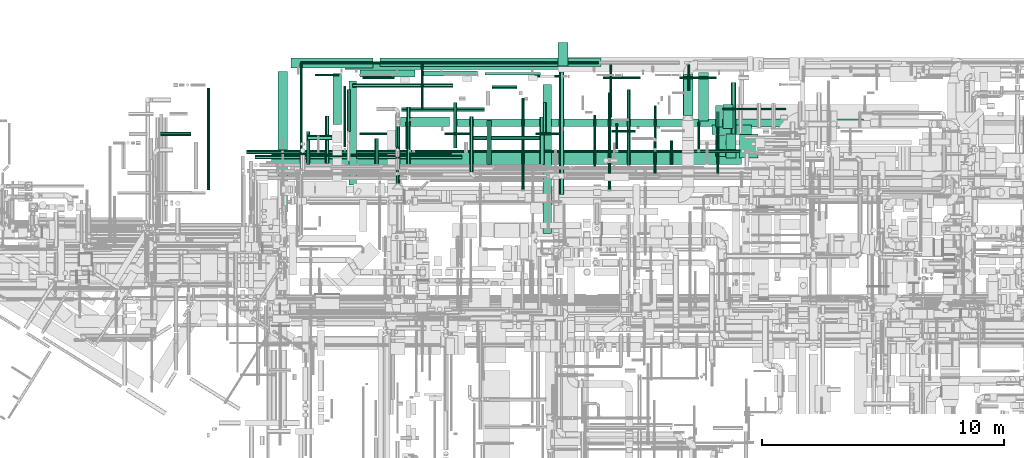
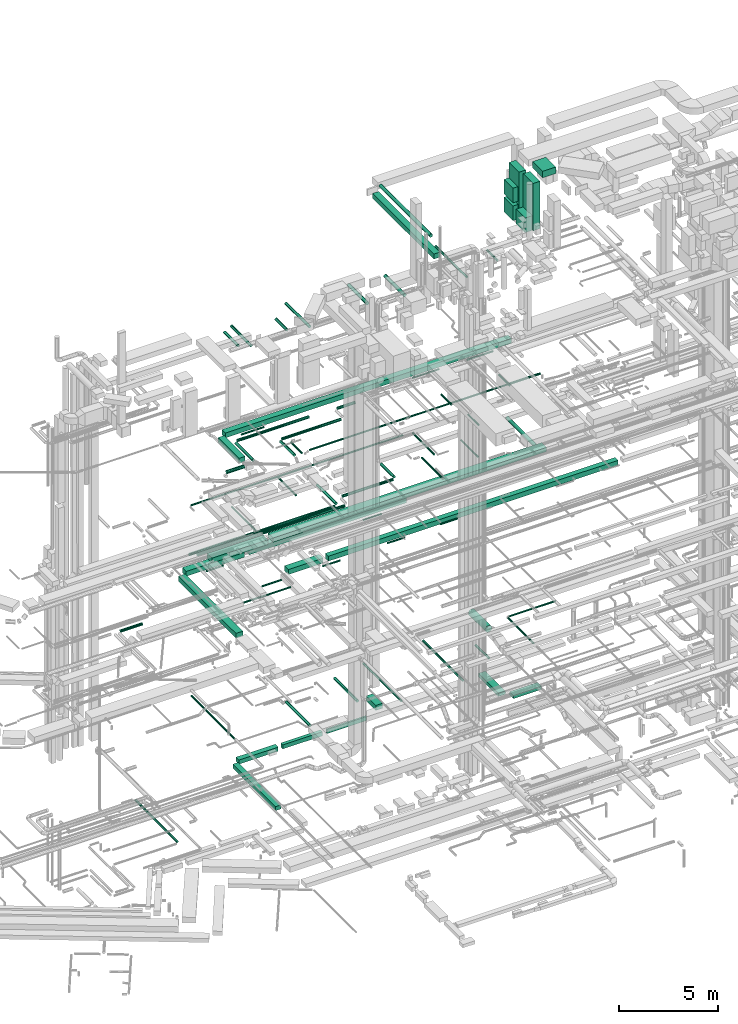
# One storey, part 36 of 337: 77 flow segments.
"""IFC2X3 building model written with IfcOpenShell, lengths in millimetres."""

from ifc_helpers import new_model, entity, si_unit, converted_unit, derived_unit, direction, frame, origin, origin_2d_with_axis, place, context, subcontext, project, spatial, rectangle, circle, extrude, type_object, element, save


model = new_model("IFC2X3")

# Units and contexts
model_context = context("Model", 3, precision=0.01, world=origin(), true_north=direction((6.12303176911189e-17, 1.0)))
body_context = subcontext(model_context, "Body", "Model", "MODEL_VIEW")
ifc_project = project(units=[si_unit("LENGTHUNIT", "METRE", prefix="MILLI"), si_unit("AREAUNIT", "SQUARE_METRE"), si_unit("VOLUMEUNIT", "CUBIC_METRE"), converted_unit("PLANEANGLEUNIT", "DEGREE", entity("IfcRatioMeasure", 0.0174532925199433), si_unit("PLANEANGLEUNIT", "RADIAN"), dimensions=[0, 0, 0, 0, 0, 0, 0]), si_unit("MASSUNIT", "GRAM", prefix="KILO"), derived_unit("MASSDENSITYUNIT", [(si_unit("MASSUNIT", "GRAM", prefix="KILO"), 1), (si_unit("LENGTHUNIT", "METRE"), -3)]), derived_unit("MOMENTOFINERTIAUNIT", [(si_unit("LENGTHUNIT", "METRE"), 4)]), si_unit("TIMEUNIT", "SECOND"), si_unit("FREQUENCYUNIT", "HERTZ"), si_unit("THERMODYNAMICTEMPERATUREUNIT", "DEGREE_CELSIUS"), derived_unit("THERMALTRANSMITTANCEUNIT", [(si_unit("MASSUNIT", "GRAM", prefix="KILO"), 1), (si_unit("THERMODYNAMICTEMPERATUREUNIT", "KELVIN"), -1), (si_unit("TIMEUNIT", "SECOND"), -3)]), derived_unit("VOLUMETRICFLOWRATEUNIT", [(si_unit("LENGTHUNIT", "METRE"), 3), (si_unit("TIMEUNIT", "SECOND"), -1)]), derived_unit("MASSFLOWRATEUNIT", [(si_unit("MASSUNIT", "GRAM", prefix="KILO"), 1), (si_unit("TIMEUNIT", "SECOND"), -1)]), derived_unit("ROTATIONALFREQUENCYUNIT", [(si_unit("TIMEUNIT", "SECOND"), -1)]), si_unit("ELECTRICCURRENTUNIT", "AMPERE"), si_unit("ELECTRICVOLTAGEUNIT", "VOLT"), si_unit("POWERUNIT", "WATT"), si_unit("FORCEUNIT", "NEWTON", prefix="KILO"), si_unit("ILLUMINANCEUNIT", "LUX"), si_unit("LUMINOUSFLUXUNIT", "LUMEN"), si_unit("LUMINOUSINTENSITYUNIT", "CANDELA"), derived_unit("USERDEFINED", [(si_unit("MASSUNIT", "GRAM", prefix="KILO"), -1), (si_unit("LENGTHUNIT", "METRE"), -2), (si_unit("TIMEUNIT", "SECOND"), 3), (si_unit("LUMINOUSFLUXUNIT", "LUMEN"), 1)]), derived_unit("LINEARVELOCITYUNIT", [(si_unit("LENGTHUNIT", "METRE"), 1), (si_unit("TIMEUNIT", "SECOND"), -1)]), si_unit("PRESSUREUNIT", "PASCAL"), derived_unit("USERDEFINED", [(si_unit("LENGTHUNIT", "METRE"), -2), (si_unit("MASSUNIT", "GRAM", prefix="KILO"), 1), (si_unit("TIMEUNIT", "SECOND"), -2)]), derived_unit("LINEARFORCEUNIT", [(si_unit("MASSUNIT", "GRAM", prefix="KILO"), 1), (si_unit("LENGTHUNIT", "METRE"), 1), (si_unit("TIMEUNIT", "SECOND"), -2), (si_unit("LENGTHUNIT", "METRE"), -1)]), derived_unit("PLANARFORCEUNIT", [(si_unit("MASSUNIT", "GRAM", prefix="KILO"), 1), (si_unit("LENGTHUNIT", "METRE"), 1), (si_unit("TIMEUNIT", "SECOND"), -2), (si_unit("LENGTHUNIT", "METRE"), -2)])], contexts=[model_context])

# Site, building, storey
site_placement = place(None, origin())
site = spatial("IfcSite", under=ifc_project, at=site_placement, CompositionType="ELEMENT")
building_placement = place(site_placement, origin())
building = spatial("IfcBuilding", under=site, at=building_placement, CompositionType="ELEMENT")
storey_placement = place(building_placement, origin())
storey = spatial("IfcBuildingStorey", under=building, at=storey_placement, CompositionType="ELEMENT", Elevation=0.0)

# Flow segments
duct_segment_type_1 = type_object("IfcDuctSegmentType", PredefinedType="NOTDEFINED")
flow_segment_1_placement = place(storey_placement, frame((35764.51, 17493.43, -700.0)))
element("IfcFlowSegment", 1, at=flow_segment_1_placement, inside=storey, type_object=duct_segment_type_1, context=body_context, shape_type="SweptSolid", body=[
    extrude(rectangle(XDim=2020.37256000017, YDim=400.0, at=origin_2d_with_axis()), frame((200.0, 1010.19, 0.0), z_axis=(0.0, 0.0, 1.0), x_axis=(0.0, -1.0, 0.0)), (0.0, 0.0, 1.0), 200.0),
])
flow_segment_2_placement = place(storey_placement, frame((21289.2, 14853.13, -1050.0)))
element("IfcFlowSegment", 2, at=flow_segment_2_placement, inside=storey, type_object=duct_segment_type_1, context=body_context, shape_type="SweptSolid", body=[
    extrude(rectangle(XDim=4310.31577104467, YDim=300.000000000001, at=origin_2d_with_axis()), frame((150.0, 2155.16, 0.0), z_axis=(0.0, 0.0, 1.0), x_axis=(0.0, 1.0, 0.0)), (0.0, 0.0, 1.0), 250.0),
])
flow_segment_3_placement = place(storey_placement, frame((26914.66, 19413.45, -1050.0)))
element("IfcFlowSegment", 3, at=flow_segment_3_placement, inside=storey, type_object=duct_segment_type_1, context=body_context, shape_type="SweptSolid", body=[
    extrude(rectangle(XDim=2300.0, YDim=99.9999999999989, at=origin_2d_with_axis()), frame((1150.0, 50.0, 0.0)), (0.0, 0.0, 1.0), 250.0),
])
flow_segment_4_placement = place(storey_placement, frame((21739.2, 19313.45, -1050.0)))
element("IfcFlowSegment", 4, at=flow_segment_4_placement, inside=storey, type_object=duct_segment_type_1, context=body_context, shape_type="SweptSolid", body=[
    extrude(rectangle(XDim=2275.06644000006, YDim=300.000000000001, at=origin_2d_with_axis()), frame((1137.53, 150.0, 0.0)), (0.0, 0.0, 1.0), 250.0),
])
flow_segment_5_placement = place(storey_placement, frame((24314.26, 19363.45, -1050.0)))
element("IfcFlowSegment", 5, at=flow_segment_5_placement, inside=storey, type_object=duct_segment_type_1, context=body_context, shape_type="SweptSolid", body=[
    extrude(rectangle(XDim=2300.39426999994, YDim=200.0, at=origin_2d_with_axis()), frame((1150.2, 100.0, 0.0)), (0.0, 0.0, 1.0), 250.0),
])
flow_segment_6_placement = place(storey_placement, frame((18341.81, 13737.88, 11250.0)))
element("IfcFlowSegment", 6, at=flow_segment_6_placement, inside=storey, type_object=duct_segment_type_1, context=body_context, shape_type="SweptSolid", body=[
    extrude(rectangle(XDim=5813.1806239971, YDim=400.0, at=origin_2d_with_axis()), frame((200.0, 2906.59, 0.0), z_axis=(0.0, 0.0, 1.0), x_axis=(0.0, -1.0, 0.0)), (0.0, 0.0, 1.0), 300.000000000001),
])
flow_segment_7_placement = place(storey_placement, frame((18891.81, 19701.06, 11250.0)))
element("IfcFlowSegment", 7, at=flow_segment_7_placement, inside=storey, type_object=duct_segment_type_1, context=body_context, shape_type="SweptSolid", body=[
    extrude(rectangle(XDim=3382.02332227926, YDim=400.0, at=origin_2d_with_axis()), frame((1691.01, 200.0, 0.0)), (0.0, 0.0, 1.0), 300.000000000001),
])
flow_segment_8_placement = place(storey_placement, frame((22573.84, 19751.06, 11250.0)))
element("IfcFlowSegment", 8, at=flow_segment_8_placement, inside=storey, type_object=duct_segment_type_1, context=body_context, shape_type="SweptSolid", body=[
    extrude(rectangle(XDim=9140.00000000006, YDim=349.999999999998, at=origin_2d_with_axis()), frame((4570.0, 175.0, 0.0), z_axis=(0.0, 0.0, 1.0), x_axis=(-1.0, 0.0, 0.0)), (0.0, 0.0, 1.0), 300.000000000001),
])
flow_segment_9_placement = place(storey_placement, frame((29948.52, 19770.01, -900.0)))
element("IfcFlowSegment", 9, at=flow_segment_9_placement, inside=storey, type_object=duct_segment_type_1, context=body_context, shape_type="SweptSolid", body=[
    extrude(rectangle(XDim=979.999999999998, YDim=400.0, at=origin_2d_with_axis()), frame((200.0, 490.0, 0.0), z_axis=(0.0, 0.0, 1.0), x_axis=(0.0, -1.0, 0.0)), (0.0, 0.0, 1.0), 300.0),
])
flow_segment_10_placement = place(storey_placement, frame((23427.07, 17270.26, 11250.0)))
element("IfcFlowSegment", 10, at=flow_segment_10_placement, inside=storey, type_object=duct_segment_type_1, context=body_context, shape_type="SweptSolid", body=[
    extrude(rectangle(XDim=2020.20776527769, YDim=400.000000000001, at=origin_2d_with_axis()), frame((1010.19, 200.42, 0.0), z_axis=(0.0, 0.0, 1.0), x_axis=(0.999999913066635, 0.000416973288061593, 0.0)), (0.0, 0.0, 1.0), 300.000000000001),
])
flow_segment_11_placement = place(storey_placement, frame((25747.36, 17278.1, 11250.0)))
element("IfcFlowSegment", 11, at=flow_segment_11_placement, inside=storey, type_object=duct_segment_type_1, context=body_context, shape_type="SweptSolid", body=[
    extrude(rectangle(XDim=16839.4591539843, YDim=299.999999999999, at=origin_2d_with_axis()), frame((8419.73, 150.07, 0.0), z_axis=(0.0, 0.0, 1.0), x_axis=(-1.0, 8.70399802487435e-06, 0.0)), (0.0, 0.0, 1.0), 300.000000000001),
])
flow_segment_12_placement = place(storey_placement, frame((18075.0, 15700.0, 14775.0)))
element("IfcFlowSegment", 12, at=flow_segment_12_placement, inside=storey, type_object=duct_segment_type_1, context=body_context, shape_type="SweptSolid", body=[
    extrude(rectangle(XDim=3253.67631212293, YDim=500.000000000001, at=origin_2d_with_axis()), frame((1626.84, 250.0, 0.0), z_axis=(0.0, 0.0, 1.0), x_axis=(-1.0, 0.0, 0.0)), (0.0, 0.0, 1.0), 300.000000000001),
])
flow_segment_13_placement = place(storey_placement, frame((20620.28, 17360.32, 19020.0)))
element("IfcFlowSegment", 13, at=flow_segment_13_placement, inside=storey, type_object=duct_segment_type_1, context=body_context, shape_type="SweptSolid", body=[
    extrude(rectangle(XDim=2114.99999999989, YDim=349.999999999998, at=origin_2d_with_axis()), frame((175.0, 1057.5, 0.0), z_axis=(0.0, 0.0, 1.0), x_axis=(0.0, 1.0, 0.0)), (0.0, 0.0, 1.0), 300.000000000001),
])
flow_segment_14_placement = place(storey_placement, frame((21120.28, 19625.32, 19020.0)))
element("IfcFlowSegment", 14, at=flow_segment_14_placement, inside=storey, type_object=duct_segment_type_1, context=body_context, shape_type="SweptSolid", body=[
    extrude(rectangle(XDim=16642.5000000001, YDim=349.999999999998, at=origin_2d_with_axis()), frame((8321.25, 175.0, 0.0)), (0.0, 0.0, 1.0), 300.000000000001),
])
flow_segment_15_placement = place(storey_placement, frame((21628.68, 15700.0, 14825.0)))
element("IfcFlowSegment", 15, at=flow_segment_15_placement, inside=storey, type_object=duct_segment_type_1, context=body_context, shape_type="SweptSolid", body=[
    extrude(rectangle(XDim=15900.0000000001, YDim=499.999999999999, at=origin_2d_with_axis()), frame((7950.0, 250.0, 0.0)), (0.0, 0.0, 1.0), 249.999999999999),
])
flow_segment_16_placement = place(storey_placement, frame((36780.03, 17184.6, 28436.05)))
element("IfcFlowSegment", 16, at=flow_segment_16_placement, inside=storey, type_object=duct_segment_type_1, context=body_context, shape_type="SweptSolid", body=[
    extrude(rectangle(XDim=1000.0, YDim=400.0, at=origin_2d_with_axis()), frame((200.0, 500.0, 0.0), z_axis=(0.0, 0.0, 1.0), x_axis=(0.0, -1.0, 0.0)), (0.0, 0.0, 1.0), 2913.95301709568),
])
flow_segment_17_placement = place(storey_placement, frame((36900.03, 15969.6, 28436.05)))
element("IfcFlowSegment", 17, at=flow_segment_17_placement, inside=storey, type_object=duct_segment_type_1, context=body_context, shape_type="SweptSolid", body=[
    extrude(rectangle(XDim=400.0, YDim=1000.0, at=origin_2d_with_axis()), frame((200.0, 500.0, 0.0), z_axis=(0.0, 0.0, 1.0), x_axis=(-1.0, 0.0, 0.0)), (0.0, 0.0, 1.0), 2913.95306709572),
])
flow_segment_18_placement = place(storey_placement, frame((37450.03, 15969.6, 31500.0)))
element("IfcFlowSegment", 18, at=flow_segment_18_placement, inside=storey, type_object=duct_segment_type_1, context=body_context, shape_type="SweptSolid", body=[
    extrude(rectangle(XDim=776.110108295712, YDim=1000.0, at=origin_2d_with_axis()), frame((388.06, 500.0, 0.0), z_axis=(0.0, 0.0, 1.0), x_axis=(-1.0, 0.0, 0.0)), (0.0, 0.0, 1.0), 399.999999999996),
])
flow_segment_19_placement = place(storey_placement, frame((36467.57, 17244.61, 29535.0)))
element("IfcFlowSegment", 19, at=flow_segment_19_placement, inside=storey, type_object=duct_segment_type_1, context=body_context, shape_type="SweptSolid", body=[
    extrude(rectangle(XDim=292.459971193469, YDim=900.000000000001, at=origin_2d_with_axis()), frame((146.23, 450.0, 0.0)), (0.0, 0.0, 1.0), 900.000000000003),
])
flow_segment_20_placement = place(storey_placement, frame((36467.57, 17244.61, 28445.0)))
element("IfcFlowSegment", 20, at=flow_segment_20_placement, inside=storey, type_object=duct_segment_type_1, context=body_context, shape_type="SweptSolid", body=[
    extrude(rectangle(XDim=292.460689670469, YDim=899.999999999999, at=origin_2d_with_axis()), frame((146.23, 450.0, 0.0), z_axis=(0.0, 0.0, 1.0), x_axis=(-1.0, 0.0, 0.0)), (0.0, 0.0, 1.0), 900.000000000003),
])
flow_segment_21_placement = place(storey_placement, frame((36467.57, 16029.61, 28445.0)))
element("IfcFlowSegment", 21, at=flow_segment_21_placement, inside=storey, type_object=duct_segment_type_1, context=body_context, shape_type="SweptSolid", body=[
    extrude(rectangle(XDim=412.460464894217, YDim=899.999999999999, at=origin_2d_with_axis()), frame((206.23, 450.0, 0.0), z_axis=(0.0, 0.0, 1.0), x_axis=(-1.0, 1.78893262287182e-06, 0.0)), (0.0, 0.0, 1.0), 900.000000000003),
])
flow_segment_22_placement = place(storey_placement, frame((36314.51, 16943.43, -700.0)))
element("IfcFlowSegment", 22, at=flow_segment_22_placement, inside=storey, type_object=duct_segment_type_1, context=body_context, shape_type="SweptSolid", body=[
    extrude(rectangle(XDim=1644.99999999996, YDim=400.0, at=origin_2d_with_axis()), frame((822.5, 200.0, 0.0)), (0.0, 0.0, 1.0), 200.0),
])
flow_segment_23_placement = place(storey_placement, frame((29324.08, 12849.99, 31250.0)))
element("IfcFlowSegment", 23, at=flow_segment_23_placement, inside=storey, type_object=duct_segment_type_1, context=body_context, shape_type="SweptSolid", body=[
    extrude(rectangle(XDim=6156.91850813843, YDim=349.999999999998, at=origin_2d_with_axis()), frame((175.0, 3078.46, 0.0), z_axis=(0.0, 0.0, 1.0), x_axis=(0.0, 1.0, 0.0)), (0.0, 0.0, 1.0), 300.000000000001),
])
duct_segment_type_2 = type_object("IfcDuctSegmentType", PredefinedType="NOTDEFINED")
flow_segment_24_placement = place(storey_placement, frame((15405.54, 14654.63, -864.1)))
element("IfcFlowSegment", 24, at=flow_segment_24_placement, inside=storey, type_object=duct_segment_type_2, context=body_context, shape_type="SweptSolid", body=[
    extrude(circle(Radius=62.5, at=origin_2d_with_axis()), frame((64.1, 0.0, 64.1), z_axis=(0.0, 1.0, 0.0), x_axis=(1.0, 0.0, 0.0)), (0.0, 0.0, 1.0), 4218.31335607326),
])
flow_segment_25_placement = place(storey_placement, frame((20107.3, 16025.3, 11348.4)))
element("IfcFlowSegment", 25, at=flow_segment_25_placement, inside=storey, type_object=duct_segment_type_2, context=body_context, shape_type="SweptSolid", body=[
    extrude(circle(Radius=50.0, at=origin_2d_with_axis()), frame((0.0, 51.6, 51.6), z_axis=(1.0, 0.0, 0.0), x_axis=(0.0, -1.0, 0.0)), (0.0, 0.0, 1.0), 2750.0018072251),
])
flow_segment_26_placement = place(storey_placement, frame((21722.4, 16927.64, 11248.4)))
element("IfcFlowSegment", 26, at=flow_segment_26_placement, inside=storey, type_object=duct_segment_type_2, context=body_context, shape_type="SweptSolid", body=[
    extrude(circle(Radius=50.0, at=origin_2d_with_axis()), frame((0.0, 51.6, 51.6), z_axis=(1.0, 0.0, 0.0), x_axis=(0.0, 1.0, 0.0)), (0.0, 0.0, 1.0), 1134.89753859989),
])
flow_segment_27_placement = place(storey_placement, frame((25248.81, 16927.64, 11248.4)))
element("IfcFlowSegment", 27, at=flow_segment_27_placement, inside=storey, type_object=duct_segment_type_2, context=body_context, shape_type="SweptSolid", body=[
    extrude(circle(Radius=50.0, at=origin_2d_with_axis()), frame((0.0, 51.6, 51.6), z_axis=(1.0, 0.0, 0.0), x_axis=(0.0, -1.0, 0.0)), (0.0, 0.0, 1.0), 1020.00000000001),
])
flow_segment_28_placement = place(storey_placement, frame((31412.58, 15610.0, 15273.4)))
element("IfcFlowSegment", 28, at=flow_segment_28_placement, inside=storey, type_object=duct_segment_type_2, context=body_context, shape_type="SweptSolid", body=[
    extrude(circle(Radius=50.0, at=origin_2d_with_axis()), frame((51.6, 0.0, 51.6), z_axis=(0.0, 1.0, 0.0), x_axis=(-1.0, 0.0, 0.0)), (0.0, 0.0, 1.0), 2150.29099730123),
])
flow_segment_29_placement = place(storey_placement, frame((33910.91, 16425.5, 15248.4)))
element("IfcFlowSegment", 29, at=flow_segment_29_placement, inside=storey, type_object=duct_segment_type_2, context=body_context, shape_type="SweptSolid", body=[
    extrude(circle(Radius=50.0, at=origin_2d_with_axis()), frame((51.6, 0.0, 51.6), z_axis=(0.0, 1.0, 0.0), x_axis=(-1.0, 0.0, 0.0)), (0.0, 0.0, 1.0), 1710.0),
])
flow_segment_30_placement = place(storey_placement, frame((37106.36, 16220.0, 14848.4)))
element("IfcFlowSegment", 30, at=flow_segment_30_placement, inside=storey, type_object=duct_segment_type_2, context=body_context, shape_type="SweptSolid", body=[
    extrude(circle(Radius=100.0, at=origin_2d_with_axis()), frame((101.6, 0.0, 101.6), z_axis=(0.0, 1.0, 0.0), x_axis=(-1.0, 0.0, 0.0)), (0.0, 0.0, 1.0), 2877.5316573013),
])
flow_segment_31_placement = place(storey_placement, frame((28971.43, 19300.97, 11348.4)))
element("IfcFlowSegment", 31, at=flow_segment_31_placement, inside=storey, type_object=duct_segment_type_2, context=body_context, shape_type="SweptSolid", body=[
    extrude(circle(Radius=50.0, at=origin_2d_with_axis()), frame((0.0, 51.6, 51.6), z_axis=(1.0, 0.0, 0.0), x_axis=(0.0, 1.0, 0.0)), (0.0, 0.0, 1.0), 1073.20508075691),
])
flow_segment_32_placement = place(storey_placement, frame((29005.5, 16927.64, 11348.4)))
element("IfcFlowSegment", 32, at=flow_segment_32_placement, inside=storey, type_object=duct_segment_type_2, context=body_context, shape_type="SweptSolid", body=[
    extrude(circle(Radius=50.0, at=origin_2d_with_axis()), frame((0.0, 51.6, 51.6), z_axis=(1.0, 0.0, 0.0), x_axis=(0.0, 1.0, 0.0)), (0.0, 0.0, 1.0), 1020.00000000005),
])
flow_segment_33_placement = place(storey_placement, frame((32145.5, 17027.64, 11348.4)))
element("IfcFlowSegment", 33, at=flow_segment_33_placement, inside=storey, type_object=duct_segment_type_2, context=body_context, shape_type="SweptSolid", body=[
    extrude(circle(Radius=50.0, at=origin_2d_with_axis()), frame((0.0, 51.6, 51.6), z_axis=(1.0, 0.0, 0.0), x_axis=(0.0, 1.0, 0.0)), (0.0, 0.0, 1.0), 1000.00000000001),
])
flow_segment_34_placement = place(storey_placement, frame((13483.56, 16875.05, 11368.4)))
element("IfcFlowSegment", 34, at=flow_segment_34_placement, inside=storey, type_object=duct_segment_type_2, context=body_context, shape_type="SweptSolid", body=[
    extrude(circle(Radius=80.0, at=origin_2d_with_axis()), frame((0.0, 81.6, 81.6), z_axis=(1.0, 0.0, 0.0), x_axis=(0.0, -1.0, 0.0)), (0.0, 0.0, 1.0), 1260.00000000001),
])
flow_segment_35_placement = place(storey_placement, frame((19253.1, 15523.58, 3598.4)))
element("IfcFlowSegment", 35, at=flow_segment_35_placement, inside=storey, type_object=duct_segment_type_2, context=body_context, shape_type="SweptSolid", body=[
    extrude(circle(Radius=50.0, at=origin_2d_with_axis()), frame((51.6, 0.0, 51.6), z_axis=(0.0, 1.0, 0.0), x_axis=(1.0, 0.0, 0.0)), (0.0, 0.0, 1.0), 4379.99999999999),
])
flow_segment_36_placement = place(storey_placement, frame((35121.38, 17724.4, 3268.4)))
element("IfcFlowSegment", 36, at=flow_segment_36_placement, inside=storey, type_object=duct_segment_type_2, context=body_context, shape_type="SweptSolid", body=[
    extrude(circle(Radius=200.0, at=origin_2d_with_axis()), frame((201.6, 0.0, 201.6), z_axis=(0.0, 1.0, 0.0), x_axis=(1.0, 0.0, 0.0)), (0.0, 0.0, 1.0), 1695.00000000001),
])
flow_segment_37_placement = place(storey_placement, frame((23233.95, 14886.58, 3368.4)))
element("IfcFlowSegment", 37, at=flow_segment_37_placement, inside=storey, type_object=duct_segment_type_2, context=body_context, shape_type="SweptSolid", body=[
    extrude(circle(Radius=80.0, at=origin_2d_with_axis()), frame((81.6, 0.0, 81.6), z_axis=(0.0, 1.0, 0.0), x_axis=(-1.0, 0.0, 0.0)), (0.0, 0.0, 1.0), 2393.0059468203),
])
flow_segment_38_placement = place(storey_placement, frame((28417.78, 14646.58, 3235.9)))
element("IfcFlowSegment", 38, at=flow_segment_38_placement, inside=storey, type_object=duct_segment_type_2, context=body_context, shape_type="SweptSolid", body=[
    extrude(circle(Radius=62.5, at=origin_2d_with_axis()), frame((64.1, 0.0, 64.1), z_axis=(0.0, 1.0, 0.0), x_axis=(1.0, 0.0, 0.0)), (0.0, 0.0, 1.0), 3808.67063794792),
])
flow_segment_39_placement = place(storey_placement, frame((32008.5, 14646.58, 3235.9)))
element("IfcFlowSegment", 39, at=flow_segment_39_placement, inside=storey, type_object=duct_segment_type_2, context=body_context, shape_type="SweptSolid", body=[
    extrude(circle(Radius=62.5, at=origin_2d_with_axis()), frame((64.1, 0.0, 64.1), z_axis=(0.0, 1.0, 0.0), x_axis=(1.0, 0.0, 0.0)), (0.0, 0.0, 1.0), 4039.29225326352),
])
flow_segment_40_placement = place(storey_placement, frame((36509.66, 15324.94, 3548.4)))
element("IfcFlowSegment", 40, at=flow_segment_40_placement, inside=storey, type_object=duct_segment_type_2, context=body_context, shape_type="SweptSolid", body=[
    extrude(circle(Radius=50.0, at=origin_2d_with_axis()), frame((51.6, 0.0, 51.6), z_axis=(0.0, 1.0, 0.0), x_axis=(1.0, 0.0, 0.0)), (0.0, 0.0, 1.0), 2574.53125),
])
flow_segment_41_placement = place(storey_placement, frame((36661.25, 17947.88, 3548.4)))
element("IfcFlowSegment", 41, at=flow_segment_41_placement, inside=storey, type_object=duct_segment_type_2, context=body_context, shape_type="SweptSolid", body=[
    extrude(circle(Radius=50.0, at=origin_2d_with_axis()), frame((0.0, 51.6, 51.6), z_axis=(1.0, 0.0, 0.0), x_axis=(0.0, -1.0, 0.0)), (0.0, 0.0, 1.0), 2719.99999999999),
])
flow_segment_42_placement = place(storey_placement, frame((26271.53, 15384.94, 3518.4)))
element("IfcFlowSegment", 42, at=flow_segment_42_placement, inside=storey, type_object=duct_segment_type_2, context=body_context, shape_type="SweptSolid", body=[
    extrude(circle(Radius=80.0, at=origin_2d_with_axis()), frame((81.6, 0.0, 81.6), z_axis=(0.0, 1.0, 0.0), x_axis=(1.0, 0.0, 0.0)), (0.0, 0.0, 1.0), 2294.53125000013),
])
flow_segment_43_placement = place(storey_placement, frame((33898.43, 15324.94, 3535.9)))
element("IfcFlowSegment", 43, at=flow_segment_43_placement, inside=storey, type_object=duct_segment_type_2, context=body_context, shape_type="SweptSolid", body=[
    extrude(circle(Radius=62.5, at=origin_2d_with_axis()), frame((64.1, 0.0, 64.1), z_axis=(0.0, 1.0, 0.0), x_axis=(1.0, 0.0, 0.0)), (0.0, 0.0, 1.0), 1335.0),
])
flow_segment_44_placement = place(storey_placement, frame((19870.5, 19353.19, 11348.4)))
element("IfcFlowSegment", 44, at=flow_segment_44_placement, inside=storey, type_object=duct_segment_type_2, context=body_context, shape_type="SweptSolid", body=[
    extrude(circle(Radius=50.0, at=origin_2d_with_axis()), frame((0.0, 51.6, 51.6), z_axis=(1.0, 0.0, 0.0), x_axis=(0.0, -1.0, 0.0)), (0.0, 0.0, 1.0), 1005.56723867106),
])
flow_segment_45_placement = place(storey_placement, frame((17390.0, 15927.7, 15268.4)))
element("IfcFlowSegment", 45, at=flow_segment_45_placement, inside=storey, type_object=duct_segment_type_2, context=body_context, shape_type="SweptSolid", body=[
    extrude(circle(Radius=80.0, at=origin_2d_with_axis()), frame((0.0, 81.6, 81.6), z_axis=(1.0, 0.0, 0.0), x_axis=(0.0, -1.0, 0.0)), (0.0, 0.0, 1.0), 8580.00000000002),
])
flow_segment_46_placement = place(storey_placement, frame((26290.0, 16718.4, 15268.4)))
element("IfcFlowSegment", 46, at=flow_segment_46_placement, inside=storey, type_object=duct_segment_type_2, context=body_context, shape_type="SweptSolid", body=[
    extrude(circle(Radius=80.0, at=origin_2d_with_axis()), frame((0.0, 81.6, 81.6), z_axis=(1.0, 0.0, 0.0), x_axis=(0.0, -1.0, 0.0)), (0.0, 0.0, 1.0), 2943.3161585469),
])
flow_segment_47_placement = place(storey_placement, frame((29311.72, 16960.0, 15268.4)))
element("IfcFlowSegment", 47, at=flow_segment_47_placement, inside=storey, type_object=duct_segment_type_2, context=body_context, shape_type="SweptSolid", body=[
    extrude(circle(Radius=80.0, at=origin_2d_with_axis()), frame((81.6, 0.0, 81.6), z_axis=(0.0, 1.0, 0.0), x_axis=(1.0, 0.0, 0.0)), (0.0, 0.0, 1.0), 1299.99999999998),
])
flow_segment_48_placement = place(storey_placement, frame((34970.0, 19248.26, 19118.4)))
element("IfcFlowSegment", 48, at=flow_segment_48_placement, inside=storey, type_object=duct_segment_type_2, context=body_context, shape_type="SweptSolid", body=[
    extrude(circle(Radius=50.0, at=origin_2d_with_axis()), frame((0.0, 51.6, 51.6), z_axis=(1.0, 0.0, 0.0), x_axis=(0.0, 1.0, 0.0)), (0.0, 0.0, 1.0), 1534.95296918984),
])
flow_segment_49_placement = place(storey_placement, frame((31805.1, 19248.26, 19118.4)))
element("IfcFlowSegment", 49, at=flow_segment_49_placement, inside=storey, type_object=duct_segment_type_2, context=body_context, shape_type="SweptSolid", body=[
    extrude(circle(Radius=50.0, at=origin_2d_with_axis()), frame((0.0, 51.6, 51.6), z_axis=(1.0, 0.0, 0.0), x_axis=(0.0, 1.0, 0.0)), (0.0, 0.0, 1.0), 1554.95296918986),
])
flow_segment_50_placement = place(storey_placement, frame((21853.8, 19248.26, 19118.4)))
element("IfcFlowSegment", 50, at=flow_segment_50_placement, inside=storey, type_object=duct_segment_type_2, context=body_context, shape_type="SweptSolid", body=[
    extrude(circle(Radius=50.0, at=origin_2d_with_axis()), frame((0.0, 51.6, 51.6), z_axis=(1.0, 0.0, 0.0), x_axis=(0.0, 1.0, 0.0)), (0.0, 0.0, 1.0), 1320.00000000001),
])
flow_segment_51_placement = place(storey_placement, frame((19570.28, 16712.33, 19068.4)))
element("IfcFlowSegment", 51, at=flow_segment_51_placement, inside=storey, type_object=duct_segment_type_2, context=body_context, shape_type="SweptSolid", body=[
    extrude(circle(Radius=100.0, at=origin_2d_with_axis()), frame((0.0, 101.6, 101.6), z_axis=(1.0, 0.0, 0.0), x_axis=(0.0, 1.0, 0.0)), (0.0, 0.0, 1.0), 1005.0),
])
flow_segment_52_placement = place(storey_placement, frame((23449.37, 17892.72, 19068.4)))
element("IfcFlowSegment", 52, at=flow_segment_52_placement, inside=storey, type_object=duct_segment_type_2, context=body_context, shape_type="SweptSolid", body=[
    extrude(circle(Radius=80.0, at=origin_2d_with_axis()), frame((0.0, 81.6, 81.6), z_axis=(1.0, 0.0, 0.0), x_axis=(0.0, -1.0, 0.0)), (0.0, 0.0, 1.0), 3437.81249999998),
])
flow_segment_53_placement = place(storey_placement, frame((27207.18, 18818.81, 19068.4)))
element("IfcFlowSegment", 53, at=flow_segment_53_placement, inside=storey, type_object=duct_segment_type_2, context=body_context, shape_type="SweptSolid", body=[
    extrude(circle(Radius=80.0, at=origin_2d_with_axis()), frame((0.0, 81.6, 81.6), z_axis=(1.0, 0.0, 0.0), x_axis=(0.0, -1.0, 0.0)), (0.0, 0.0, 1.0), 1030.93750000001),
])
flow_segment_54_placement = place(storey_placement, frame((21193.27, 17076.79, 19063.4)))
element("IfcFlowSegment", 54, at=flow_segment_54_placement, inside=storey, type_object=duct_segment_type_2, context=body_context, shape_type="SweptSolid", body=[
    extrude(circle(Radius=80.0, at=origin_2d_with_axis()), frame((81.6, 0.0, 81.6), z_axis=(0.0, 1.0, 0.0), x_axis=(-1.0, 0.0, 0.0)), (0.0, 0.0, 1.0), 1738.36441008188),
])
flow_segment_55_placement = place(storey_placement, frame((21434.87, 18893.56, 19063.4)))
element("IfcFlowSegment", 55, at=flow_segment_55_placement, inside=storey, type_object=duct_segment_type_2, context=body_context, shape_type="SweptSolid", body=[
    extrude(circle(Radius=80.0, at=origin_2d_with_axis()), frame((0.0, 81.6, 81.6), z_axis=(1.0, 0.0, 0.0), x_axis=(0.0, -1.0, 0.0)), (0.0, 0.0, 1.0), 4166.25000000003),
])
flow_segment_56_placement = place(storey_placement, frame((35577.66, 16186.26, 19235.9)))
element("IfcFlowSegment", 56, at=flow_segment_56_placement, inside=storey, type_object=duct_segment_type_2, context=body_context, shape_type="SweptSolid", body=[
    extrude(circle(Radius=62.5, at=origin_2d_with_axis()), frame((0.0, 64.1, 64.1), z_axis=(1.0, 0.0, 0.0), x_axis=(0.0, -1.0, 0.0)), (0.0, 0.0, 1.0), 1895.00000000001),
])
flow_segment_57_placement = place(storey_placement, frame((24057.93, 16198.76, 19248.4)))
element("IfcFlowSegment", 57, at=flow_segment_57_placement, inside=storey, type_object=duct_segment_type_2, context=body_context, shape_type="SweptSolid", body=[
    extrude(circle(Radius=50.0, at=origin_2d_with_axis()), frame((0.0, 51.6, 51.6), z_axis=(1.0, 0.0, 0.0), x_axis=(0.0, -1.0, 0.0)), (0.0, 0.0, 1.0), 11494.7336405627),
])
flow_segment_58_placement = place(storey_placement, frame((23631.69, 16350.36, 19123.4)))
element("IfcFlowSegment", 58, at=flow_segment_58_placement, inside=storey, type_object=duct_segment_type_2, context=body_context, shape_type="SweptSolid", body=[
    extrude(circle(Radius=50.0, at=origin_2d_with_axis()), frame((51.6, 0.0, 51.6), z_axis=(0.0, 1.0, 0.0), x_axis=(1.0, 0.0, 0.0)), (0.0, 0.0, 1.0), 1100.00000000004),
])
flow_segment_59_placement = place(storey_placement, frame((32328.14, 16350.36, 19048.4)))
element("IfcFlowSegment", 59, at=flow_segment_59_placement, inside=storey, type_object=duct_segment_type_2, context=body_context, shape_type="SweptSolid", body=[
    extrude(circle(Radius=50.0, at=origin_2d_with_axis()), frame((51.6, 0.0, 51.6), z_axis=(0.0, 1.0, 0.0), x_axis=(1.0, 0.0, 0.0)), (0.0, 0.0, 1.0), 1051.75856082898),
])
flow_segment_60_placement = place(storey_placement, frame((35711.99, 16350.36, 19048.4)))
element("IfcFlowSegment", 60, at=flow_segment_60_placement, inside=storey, type_object=duct_segment_type_2, context=body_context, shape_type="SweptSolid", body=[
    extrude(circle(Radius=50.0, at=origin_2d_with_axis()), frame((51.6, 0.0, 51.6), z_axis=(0.0, 1.0, 0.0), x_axis=(-1.0, 0.0, 0.0)), (0.0, 0.0, 1.0), 1099.87598099854),
])
flow_segment_61_placement = place(storey_placement, frame((17044.94, 16137.66, 15268.4)))
element("IfcFlowSegment", 61, at=flow_segment_61_placement, inside=storey, type_object=duct_segment_type_2, context=body_context, shape_type="SweptSolid", body=[
    extrude(circle(Radius=80.0, at=origin_2d_with_axis()), frame((0.0, 81.6, 81.6), z_axis=(1.0, 0.0, 0.0), x_axis=(0.0, -1.0, 0.0)), (0.0, 0.0, 1.0), 8480.00000000001),
])
flow_segment_62_placement = place(storey_placement, frame((25603.35, 16379.26, 15268.4)))
element("IfcFlowSegment", 62, at=flow_segment_62_placement, inside=storey, type_object=duct_segment_type_2, context=body_context, shape_type="SweptSolid", body=[
    extrude(circle(Radius=80.0, at=origin_2d_with_axis()), frame((81.6, 0.0, 81.6), z_axis=(0.0, 1.0, 0.0), x_axis=(1.0, 0.0, 0.0)), (0.0, 0.0, 1.0), 1890.74263404489),
])
flow_segment_63_placement = place(storey_placement, frame((23207.77, 16416.84, 19068.4)))
element("IfcFlowSegment", 63, at=flow_segment_63_placement, inside=storey, type_object=duct_segment_type_2, context=body_context, shape_type="SweptSolid", body=[
    extrude(circle(Radius=80.0, at=origin_2d_with_axis()), frame((81.6, 0.0, 81.6), z_axis=(0.0, 1.0, 0.0), x_axis=(-1.0, 0.0, 0.0)), (0.0, 0.0, 1.0), 1397.47583002029),
])
flow_segment_64_placement = place(storey_placement, frame((21056.76, 16425.0, 15153.4)))
element("IfcFlowSegment", 64, at=flow_segment_64_placement, inside=storey, type_object=duct_segment_type_2, context=body_context, shape_type="SweptSolid", body=[
    extrude(circle(Radius=50.0, at=origin_2d_with_axis()), frame((51.6, 0.0, 51.6), z_axis=(0.0, 1.0, 0.0), x_axis=(1.0, 0.0, 0.0)), (0.0, 0.0, 1.0), 2525.00000000002),
])
flow_segment_65_placement = place(storey_placement, frame((35302.09, 18763.88, 15298.4)))
element("IfcFlowSegment", 65, at=flow_segment_65_placement, inside=storey, type_object=duct_segment_type_2, context=body_context, shape_type="SweptSolid", body=[
    extrude(circle(Radius=50.0, at=origin_2d_with_axis()), frame((51.6, 0.0, 51.6), z_axis=(0.0, 1.0, 0.0), x_axis=(-1.0, 0.0, 0.0)), (0.0, 0.0, 1.0), 1079.99999999998),
])
flow_segment_66_placement = place(storey_placement, frame((19284.14, 19862.29, 15298.4)))
element("IfcFlowSegment", 66, at=flow_segment_66_placement, inside=storey, type_object=duct_segment_type_2, context=body_context, shape_type="SweptSolid", body=[
    extrude(circle(Radius=50.0, at=origin_2d_with_axis()), frame((0.0, 51.6, 51.6), z_axis=(1.0, 0.0, 0.0), x_axis=(0.0, 1.0, 0.0)), (0.0, 0.0, 1.0), 12322.8650621681),
])
flow_segment_67_placement = place(storey_placement, frame((24260.93, 18013.88, 15298.4)))
element("IfcFlowSegment", 67, at=flow_segment_67_placement, inside=storey, type_object=duct_segment_type_2, context=body_context, shape_type="SweptSolid", body=[
    extrude(circle(Radius=50.0, at=origin_2d_with_axis()), frame((51.6, 0.0, 51.6), z_axis=(0.0, 1.0, 0.0), x_axis=(-1.0, 0.0, 0.0)), (0.0, 0.0, 1.0), 1829.99999999999),
])
flow_segment_68_placement = place(storey_placement, frame((32077.45, 17651.38, 15298.4)))
element("IfcFlowSegment", 68, at=flow_segment_68_placement, inside=storey, type_object=duct_segment_type_2, context=body_context, shape_type="SweptSolid", body=[
    extrude(circle(Radius=50.0, at=origin_2d_with_axis()), frame((51.6, 0.0, 51.6), z_axis=(0.0, 1.0, 0.0), x_axis=(-1.0, 0.0, 0.0)), (0.0, 0.0, 1.0), 2179.99999999999),
])
flow_segment_69_placement = place(storey_placement, frame((34584.13, 15675.03, 27535.9)))
element("IfcFlowSegment", 69, at=flow_segment_69_placement, inside=storey, type_object=duct_segment_type_2, context=body_context, shape_type="SweptSolid", body=[
    extrude(circle(Radius=62.5, at=origin_2d_with_axis()), frame((64.1, 0.0, 64.1), z_axis=(0.0, 1.0, 0.0), x_axis=(1.0, 0.0, 0.0)), (0.0, 0.0, 1.0), 1016.40000000001),
])
flow_segment_70_placement = place(storey_placement, frame((19518.63, 15695.03, 27518.4)))
element("IfcFlowSegment", 70, at=flow_segment_70_placement, inside=storey, type_object=duct_segment_type_2, context=body_context, shape_type="SweptSolid", body=[
    extrude(circle(Radius=80.0, at=origin_2d_with_axis()), frame((81.6, 0.0, 81.6), z_axis=(0.0, 1.0, 0.0), x_axis=(1.0, 0.0, 0.0)), (0.0, 0.0, 1.0), 1381.39999999998),
])
flow_segment_71_placement = place(storey_placement, frame((22344.01, 15695.03, 27518.4)))
element("IfcFlowSegment", 71, at=flow_segment_71_placement, inside=storey, type_object=duct_segment_type_2, context=body_context, shape_type="SweptSolid", body=[
    extrude(circle(Radius=80.0, at=origin_2d_with_axis()), frame((81.6, 0.0, 81.6), z_axis=(0.0, 1.0, 0.0), x_axis=(1.0, 0.0, 0.0)), (0.0, 0.0, 1.0), 1081.40000000001),
])
flow_segment_72_placement = place(storey_placement, frame((26990.88, 15670.03, 27498.4)))
element("IfcFlowSegment", 72, at=flow_segment_72_placement, inside=storey, type_object=duct_segment_type_2, context=body_context, shape_type="SweptSolid", body=[
    extrude(circle(Radius=100.0, at=origin_2d_with_axis()), frame((101.6, 0.0, 101.6), z_axis=(0.0, 1.0, 0.0), x_axis=(1.0, 0.0, 0.0)), (0.0, 0.0, 1.0), 1861.39999999999),
])
flow_segment_73_placement = place(storey_placement, frame((20293.33, 15741.99, 27238.4)))
element("IfcFlowSegment", 73, at=flow_segment_73_placement, inside=storey, type_object=duct_segment_type_2, context=body_context, shape_type="SweptSolid", body=[
    extrude(circle(Radius=80.0, at=origin_2d_with_axis()), frame((81.6, 0.0, 81.6), z_axis=(0.0, 1.0, 0.0), x_axis=(1.0, 0.0, 0.0)), (0.0, 0.0, 1.0), 1975.91003012475),
])
flow_segment_74_placement = place(storey_placement, frame((23666.27, 15701.99, 27238.4)))
element("IfcFlowSegment", 74, at=flow_segment_74_placement, inside=storey, type_object=duct_segment_type_2, context=body_context, shape_type="SweptSolid", body=[
    extrude(circle(Radius=80.0, at=origin_2d_with_axis()), frame((81.6, 0.0, 81.6), z_axis=(0.0, 1.0, 0.0), x_axis=(1.0, 0.0, 0.0)), (0.0, 0.0, 1.0), 2375.91003012474),
])
flow_segment_75_placement = place(storey_placement, frame((29178.69, 15701.99, 27218.4)))
element("IfcFlowSegment", 75, at=flow_segment_75_placement, inside=storey, type_object=duct_segment_type_2, context=body_context, shape_type="SweptSolid", body=[
    extrude(circle(Radius=100.0, at=origin_2d_with_axis()), frame((101.6, 0.0, 101.6), z_axis=(0.0, 1.0, 0.0), x_axis=(1.0, 0.0, 0.0)), (0.0, 0.0, 1.0), 1955.91003012473),
])
flow_segment_76_placement = place(storey_placement, frame((32805.05, 15664.49, 27135.9)))
element("IfcFlowSegment", 76, at=flow_segment_76_placement, inside=storey, type_object=duct_segment_type_2, context=body_context, shape_type="SweptSolid", body=[
    extrude(circle(Radius=62.5, at=origin_2d_with_axis()), frame((64.1, 0.0, 64.1), z_axis=(0.0, 1.0, 0.0), x_axis=(1.0, 0.0, 0.0)), (0.0, 0.0, 1.0), 3135.91003012473),
])
flow_segment_77_placement = place(storey_placement, frame((29987.63, 14453.64, 31348.4)))
element("IfcFlowSegment", 77, at=flow_segment_77_placement, inside=storey, type_object=duct_segment_type_2, context=body_context, shape_type="SweptSolid", body=[
    extrude(circle(Radius=100.0, at=origin_2d_with_axis()), frame((101.6, 0.0, 101.6), z_axis=(0.0, 1.0, 0.0), x_axis=(-1.0, 0.0, 0.0)), (0.0, 0.0, 1.0), 5080.96486327881),
])

save(model, "model.ifc")
